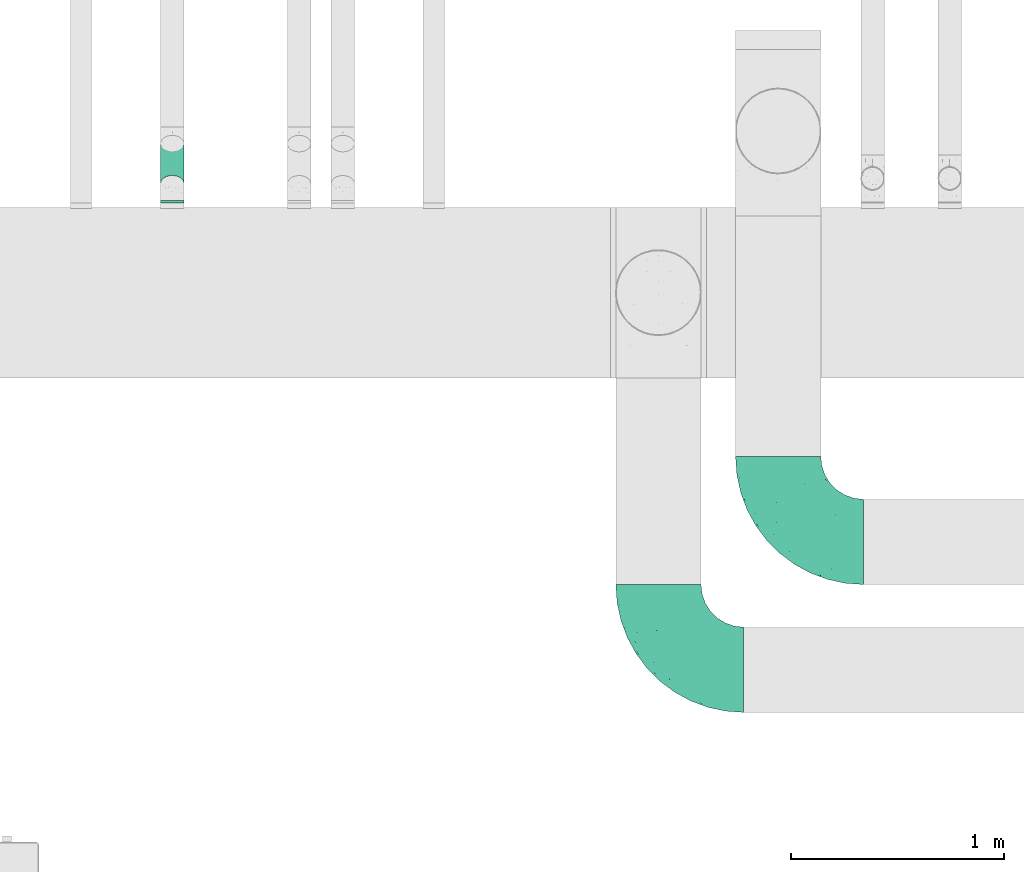
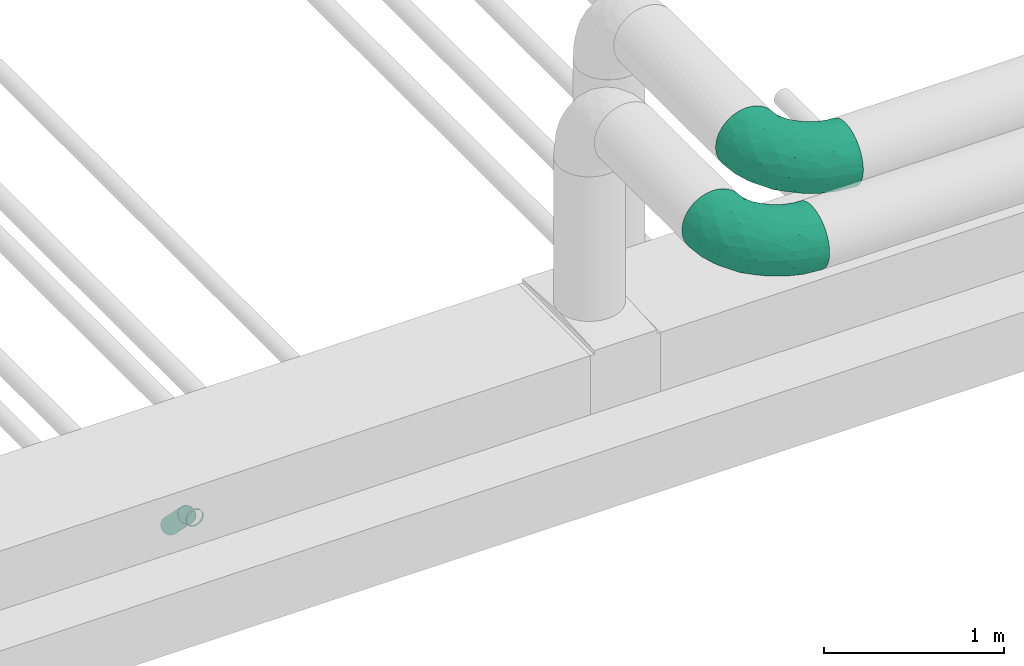
# One storey, part 32 of 91: 2 flow fittings, 2 flow segments.
"""IFC2X3 building model written with IfcOpenShell, lengths in millimetres."""

from ifc_helpers import new_model, entity, si_unit, converted_unit, derived_unit, direction, frame, origin_with_axes, origin_2d_with_axis, place, context, subcontext, project, spatial, hollow_circle, extrude, open_shell, surface_model, source, transform, mapped, material, layer, layer_set, layer_usage, type_object, element, save


model = new_model("IFC2X3")

# Units and contexts
model_context = context("Model", 3, precision=1e-05, world=origin_with_axes(), true_north=direction((0.0, 1.0)))
body_context = subcontext(model_context, "Body", "Model", "MODEL_VIEW")
ifc_project = project(units=[si_unit("AREAUNIT", "SQUARE_METRE"), si_unit("VOLUMEUNIT", "CUBIC_METRE", prefix="DECI"), si_unit("TIMEUNIT", "SECOND"), si_unit("THERMODYNAMICTEMPERATUREUNIT", "DEGREE_CELSIUS"), si_unit("PRESSUREUNIT", "PASCAL"), si_unit("MASSUNIT", "GRAM", prefix="KILO"), si_unit("LENGTHUNIT", "METRE", prefix="MILLI"), si_unit("POWERUNIT", "WATT"), si_unit("ELECTRICCURRENTUNIT", "AMPERE"), si_unit("ELECTRICVOLTAGEUNIT", "VOLT"), derived_unit("VOLUMETRICFLOWRATEUNIT", [(si_unit("VOLUMEUNIT", "CUBIC_METRE", prefix="DECI"), 1), (si_unit("TIMEUNIT", "SECOND"), -1)]), derived_unit("LINEARVELOCITYUNIT", [(si_unit("LENGTHUNIT", "METRE"), 1), (si_unit("TIMEUNIT", "SECOND"), -1)]), derived_unit("MASSDENSITYUNIT", [(si_unit("MASSUNIT", "GRAM", prefix="KILO"), 1), (si_unit("VOLUMEUNIT", "CUBIC_METRE"), -1)]), converted_unit("PLANEANGLEUNIT", "DEGREE", entity("IfcRatioMeasure", 0.01745), si_unit("PLANEANGLEUNIT", "RADIAN"), dimensions=[0, 0, 0, 0, 0, 0, 0])], contexts=[model_context])

# Site, building, storey
site_placement = place(None, origin_with_axes())
site = spatial("IfcSite", under=ifc_project, at=site_placement, CompositionType="ELEMENT")
building_placement = place(site_placement, origin_with_axes())
building = spatial("IfcBuilding", under=site, at=building_placement, Name="mc-building", CompositionType="ELEMENT")
storey_placement = place(building_placement, frame((0.0, 0.0, 8700.0), z_axis=(0.0, 0.0, 1.0), x_axis=(1.0, 0.0, 0.0)))
storey = spatial("IfcBuildingStorey", under=building, at=storey_placement, CompositionType="ELEMENT", Elevation=8700.0)

# Flow segments
ifc_material = material(Name="FZ1")
ifc_layer = layer(ifc_material, 0.0)
ifc_layer_set = layer_set([ifc_layer], Name="FZ1")
ifc_layer_usage = layer_usage(ifc_layer_set, "AXIS1", "POSITIVE", 0.0)
duct_segment_type = type_object("IfcDuctSegmentType", PredefinedType="RIGIDSEGMENT")
shared_shape_1 = source(origin_with_axes(), body_context, "Body", "SweptSolid", [
    extrude(hollow_circle(Radius=55.0, WallThickness=2.0, at=origin_2d_with_axis()), frame((0.0, 0.0, 0.0), z_axis=(1.0, 0.0, 0.0), x_axis=(0.0, 1.0, 0.0)), (0.0, 0.0, 1.0), 266.7),
])
flow_segment_1_placement = place(storey_placement, frame((14957.14677, 8401.1274, 635.78175), z_axis=(0.0, 0.707107, 0.707107), x_axis=(0.0, 0.707107, -0.707107)))
element("IfcFlowSegment", 1, at=flow_segment_1_placement, inside=storey, type_object=duct_segment_type, material=ifc_layer_usage, context=body_context, shape_type="MappedRepresentation", body=[
    mapped(shared_shape_1, transform((0.0, 0.0, 0.0), scale=1.0)),
])
shared_shape_2 = source(origin_with_axes(), body_context, "Body", "SweptSolid", [
    extrude(hollow_circle(Radius=55.0, WallThickness=2.0, at=origin_2d_with_axis()), frame((0.0, 0.0, 0.0), z_axis=(1.0, 0.0, 0.0), x_axis=(0.0, 1.0, 0.0)), (0.0, 0.0, 1.0), 13.0),
])
flow_segment_2_placement = place(storey_placement, frame((14957.14677, 8310.34565, 668.0), z_axis=(0.0, 0.0, 1.0), x_axis=(0.0, 1.0, 0.0)))
element("IfcFlowSegment", 2, at=flow_segment_2_placement, inside=storey, type_object=duct_segment_type, material=ifc_layer_usage, context=body_context, shape_type="MappedRepresentation", body=[
    mapped(shared_shape_2, transform((0.0, 0.0, 0.0), scale=1.0, scale2=1.0, scale3=1.0, uniform=False)),
])

# Flow fittings
duct_fitting_type = type_object("IfcDuctFittingType", Name="BU", PredefinedType="BEND")
shared_shape_3 = source(origin_with_axes(), body_context, "Body", "SurfaceModel", [
    surface_model("IfcShellBasedSurfaceModel", [(-400.0, 0.0, -200.0), (-400.0, -44.50419, -194.98559), (-400.0, 44.50419, -194.98559), (-400.0, 194.98559, 44.50419), (-400.0, 86.77674, -180.19378), (-400.0, 180.19378, -86.77674), (-400.0, 156.36629, -124.69796), (-400.0, 124.69796, -156.36629), (-400.0, -200.0, 0.0), (-400.0, -180.19378, 86.77674), (-400.0, -124.69796, -156.36629), (-400.0, -86.77674, -180.19378), (-400.0, -156.36629, -124.69796), (-400.0, -180.19378, -86.77674), (-400.0, -194.98559, -44.50419), (-400.0, 194.98559, -44.50419), (-400.0, 180.19378, 86.77674), (-400.0, 156.36629, 124.69796), (-400.0, 124.69796, 156.36629), (-400.0, 86.77674, 180.19378), (-400.0, 0.0, 200.0), (-400.0, 44.50419, 194.98559), (-400.0, -156.36629, 124.69796), (-400.0, -124.69796, 156.36629), (-400.0, -194.98559, 44.50419), (-400.0, -86.77674, 180.19378), (-400.0, -44.50419, 194.98559), (-400.0, 200.0, 0.0), (-194.98559, 400.0, 44.50419), (0.0, 400.0, -200.0), (-44.50419, 400.0, -194.98559), (-86.77674, 400.0, -180.19378), (-156.36629, 400.0, -124.69796), (-180.19378, 400.0, -86.77674), (-200.0, 400.0, 0.0), (-124.69796, 400.0, -156.36629), (156.36629, 400.0, -124.69796), (194.98559, 400.0, 44.50419), (86.77674, 400.0, -180.19378), (44.50419, 400.0, -194.98559), (124.69796, 400.0, -156.36629), (180.19378, 400.0, -86.77674), (194.98559, 400.0, -44.50419), (200.0, 400.0, 0.0), (-194.98559, 400.0, -44.50419), (-180.19378, 400.0, 86.77674), (-156.36629, 400.0, 124.69796), (-86.77674, 400.0, 180.19378), (-124.69796, 400.0, 156.36629), (-44.50419, 400.0, 194.98559), (124.69796, 400.0, 156.36629), (180.19378, 400.0, 86.77674), (156.36629, 400.0, 124.69796), (44.50419, 400.0, 194.98559), (86.77674, 400.0, 180.19378), (0.0, 400.0, 200.0), (-311.04439, 68.01314, 191.91169), (-360.46844, 68.4039, 188.77667), (-352.32006, 35.77277, 197.31443), (-330.54073, 6.0769, 200.0), (-263.19195, 24.12295, 200.0), (-213.51486, 270.31924, 100.59997), (-187.15609, 311.12218, 106.40641), (-204.91231, 317.36362, 67.86963), (-200.0, 53.58984, 200.0), (-197.74345, 111.1477, 194.30767), (-247.23242, 72.38885, 196.25526), (-256.68864, 256.68864, 32.58839), (-289.82519, 224.65778, 52.75457), (-248.54408, 248.5441, 73.99336), (-243.63371, 275.30204, 0.0), (-275.30204, 243.63371, 0.0), (-142.1827, 142.1827, 196.84374), (-142.88496, 93.58222, 200.0), (-271.45089, 124.32551, 175.54833), (-220.85071, 146.63576, 178.75804), (-259.76957, 175.46191, 147.316), (-350.66929, 110.58045, 169.34484), (-340.12953, 148.44794, 141.42136), (-308.54163, 188.2521, 106.4064), (-351.09401, 194.51642, 66.05581), (-361.24445, 172.62407, 106.40641), (-360.07224, 201.09774, 33.76184), (-300.36348, 163.70814, 139.24948), (-311.87682, 130.51714, 162.58441), (-194.26672, 352.15536, 66.05581), (-199.37996, 369.83655, 33.78914), (-206.63477, 338.94363, 33.20511), (-93.58222, 142.88496, 200.0), (-53.58984, 200.0, 200.0), (-111.1477, 197.74345, 194.30767), (-317.55983, 204.17269, 69.52389), (-333.06107, 208.69956, 32.59419), (-313.22325, 219.80622, 0.0), (-355.49582, 205.01441, 0.0), (-24.12295, 263.19195, 200.0), (-6.0769, 330.54073, 200.0), (-68.56573, 311.19245, 191.74293), (-217.40303, 217.40306, 141.07295), (-260.37399, 213.70418, 109.76458), (-125.42721, 271.96463, 174.87928), (-174.99626, 268.83246, 143.26342), (-163.21769, 225.3825, 169.72807), (-72.38885, 247.23242, 196.25526), (-35.77867, 352.31316, 197.31361), (-148.14225, 341.4288, 141.42136), (-110.51136, 351.07639, 169.34484), (-172.56981, 361.56427, 106.40641), (-224.65778, 289.82519, 52.75457), (-216.74424, 312.71216, 34.40997), (-68.38951, 360.58933, 188.77667), (-205.01441, 355.49582, 0.0), (-101.81453, 306.09531, 179.9031), (-130.71004, 312.65493, 162.27954), (-160.73603, 304.83801, 140.32812), (-143.50466, 203.50273, 184.62979), (-170.45511, 170.45511, 185.25303), (-314.32991, 100.10105, 179.54827), (-231.94286, 241.59953, 106.86055), (-203.62398, 249.73912, 129.12471), (-203.18683, 188.09564, 166.50592), (-219.80622, 313.22325, 0.0), (-361.56427, 172.56981, -106.40641), (-311.12218, 187.15609, -106.4064), (-341.4288, 148.14225, -141.42136), (-369.83655, 199.37996, -33.78914), (-360.58933, 68.38951, -188.77667), (-352.31316, 35.77867, -197.31361), (-304.83801, 160.73603, -140.32812), (-268.83248, 174.99626, -143.26341), (-271.96463, 125.42721, -174.87928), (-270.31924, 213.51487, -100.59997), (-351.07639, 110.51136, -169.34484), (-312.71216, 216.74424, -34.40997), (-289.82519, 224.65778, -52.75457), (-317.36362, 204.91231, -67.86963), (-352.15536, 194.26672, -66.05581), (-68.01314, 311.04439, -191.91169), (-68.4039, 360.4684, -188.77667), (-35.77277, 352.32006, -197.31443), (-142.1827, 142.1827, -196.84374), (-111.1477, 197.74345, -194.30767), (-93.58222, 142.88496, -200.0), (-142.88496, 93.58222, -200.0), (-200.0, 53.58984, -200.0), (-197.74345, 111.1477, -194.30767), (-204.17269, 317.55983, -69.52389), (-208.69954, 333.06107, -32.5942), (-194.51642, 351.09401, -66.05581), (-217.40303, 217.40306, -141.07295), (-213.70418, 260.37401, -109.76458), (-175.46191, 259.76955, -147.316), (-256.68864, 256.68864, -32.58839), (-247.23242, 72.38885, -196.25526), (-188.2521, 308.54167, -106.40641), (-172.62407, 361.24445, -106.40641), (-225.3825, 163.21769, -169.72807), (-203.50273, 143.50466, -184.62979), (-224.65778, 289.82519, -52.75457), (-248.54408, 248.5441, -73.99336), (-263.19195, 24.12295, -200.0), (-124.32551, 271.45089, -175.54831), (-163.70814, 300.36348, -139.24948), (-130.51714, 311.87682, -162.58441), (-148.44794, 340.12953, -141.42136), (-110.58045, 350.66929, -169.34484), (-201.09774, 360.07224, -33.76184), (-338.94363, 206.63477, -33.20511), (-146.63576, 220.85071, -178.75804), (-53.58984, 200.0, -200.0), (-72.38885, 247.23242, -196.25526), (-24.12295, 263.19195, -200.0), (-330.54073, 6.0769, -200.0), (-311.19245, 68.56573, -191.74293), (-6.0769, 330.54073, -200.0), (-306.09531, 101.81453, -179.9031), (-312.65497, 130.71004, -162.27954), (-170.45511, 170.45511, -185.25303), (-100.10105, 314.32991, -179.54827), (-241.59952, 231.94287, -106.86055), (-249.73912, 203.62398, -129.1247), (-188.09562, 203.18687, -166.50592), (-184.86177, -7.68945, -190.47945), (-47.3167, 68.9898, -181.64929), (43.28019, 97.94399, -146.26158), (-89.73868, -8.19462, -165.20748), (-284.08539, -23.9259, -196.06307), (-237.5194, -91.23123, -161.91366), (-285.29972, -62.21993, -184.899), (-107.30881, 56.88415, -193.38949), (-40.67465, 138.05292, -194.94777), (-131.25683, -108.81981, -96.04201), (-173.32759, -100.47387, -132.95037), (-35.15296, -20.32579, -124.42291), (108.22035, 131.82436, -97.48026), (127.15077, 249.03547, -134.14487), (162.73774, 297.11528, -101.94821), (45.84323, 55.57656, -115.34749), (15.96955, -15.96955, -67.48698), (-7.08356, -53.44974, 0.0), (53.44974, 7.08356, 0.0), (-304.96267, -182.15098, -62.88188), (66.48451, 298.1029, -184.38073), (23.16668, 169.83785, -182.54712), (22.2395, 260.55544, -194.94777), (-314.6111, -193.89287, 0.0), (-267.95143, -157.40498, -100.64249), (-150.75099, -145.7792, 0.0), (-230.96047, -175.69578, 0.0), (-197.18453, -157.02261, -53.19126), (-79.21044, -98.23441, -53.99454), (-294.12651, -135.91456, -136.39782), (156.86435, 197.34569, -53.92463), (98.27322, 80.18275, -55.7234), (101.78843, 289.17601, -164.41149), (86.29858, 191.80922, -152.84552), (97.15018, 155.27637, -127.46493), (182.19126, 305.22832, -62.89092), (104.75212, 75.61551, 0.0), (145.7792, 150.75099, 0.0), (-75.61551, -104.75212, 0.0), (193.89287, 314.6111, 0.0), (175.69578, 230.96047, 0.0), (98.27322, 80.18275, 55.7234), (-267.95143, -157.40498, 100.64249), (-197.18453, -157.02261, 53.19126), (-131.25683, -108.81981, 96.04201), (-304.96267, -182.15098, 62.88188), (108.22035, 131.82436, 97.48026), (156.86435, 197.34569, 53.92463), (162.73774, 297.11528, 101.94821), (-79.21044, -98.23441, 53.99454), (93.17167, 148.03003, 127.83594), (127.15077, 249.03547, 134.14487), (86.29858, 191.80922, 152.84552), (15.96955, -15.96955, 67.48698), (-173.32759, -100.47387, 132.95037), (-237.5194, -91.23123, 161.91366), (-294.12651, -135.91456, 136.39782), (-284.08539, -23.9259, 196.06307), (182.19126, 305.22832, 62.89092), (23.16668, 169.83785, 182.54712), (101.78843, 289.17601, 164.41149), (66.48451, 298.1029, 184.38073), (-107.30881, 56.88415, 193.38949), (-285.29972, -62.21993, 184.899), (-184.86177, -7.68945, 190.47945), (22.2395, 260.55544, 194.94777), (-40.67465, 138.05292, 194.94777), (-47.3167, 68.9898, 181.64929), (45.25548, 52.88294, 113.64735), (-89.73868, -8.19462, 165.20748), (43.28019, 97.94399, 146.26158), (-35.15296, -20.32579, 124.42291)], [open_shell([[[0, 1, 2]], [[2, 3, 4]], [[3, 5, 6]], [[6, 7, 3]], [[3, 7, 4]], [[2, 8, 9]], [[10, 8, 11]], [[2, 1, 11]], [[8, 12, 13]], [[13, 14, 8]], [[8, 10, 12]], [[11, 8, 2]], [[5, 3, 15]], [[2, 16, 3]], [[17, 16, 2]], [[18, 2, 19]], [[19, 2, 20]], [[2, 18, 17]], [[19, 20, 21]], [[22, 23, 9]], [[8, 24, 9]], [[25, 26, 20]], [[20, 23, 25]], [[9, 23, 20]], [[2, 9, 20]], [[27, 15, 3]], [[28, 29, 30]], [[31, 28, 30]], [[32, 33, 34]], [[34, 35, 32]], [[31, 35, 34]], [[36, 29, 37]], [[29, 38, 39]], [[29, 40, 38]], [[40, 29, 36]], [[36, 37, 41]], [[42, 41, 37]], [[42, 37, 43]], [[44, 34, 33]], [[28, 45, 29]], [[29, 45, 46]], [[47, 29, 48]], [[29, 47, 49]], [[46, 48, 29]], [[50, 29, 49]], [[51, 50, 52]], [[37, 29, 51]], [[53, 54, 49]], [[29, 50, 51]], [[49, 54, 50]], [[53, 49, 55]], [[34, 28, 31]], [[56, 57, 58]], [[20, 59, 58]], [[60, 56, 59]], [[61, 62, 63]], [[64, 65, 66]], [[67, 68, 69]], [[60, 64, 66]], [[70, 71, 67]], [[72, 65, 73]], [[74, 75, 76]], [[77, 18, 19]], [[64, 73, 65]], [[17, 18, 78]], [[79, 80, 81]], [[27, 3, 82]], [[74, 83, 84]], [[16, 17, 81]], [[85, 86, 87]], [[81, 17, 78]], [[19, 21, 57]], [[88, 89, 90]], [[80, 3, 16]], [[91, 92, 80]], [[78, 18, 77]], [[92, 93, 94]], [[95, 96, 97]], [[88, 72, 73]], [[66, 74, 56]], [[98, 99, 76]], [[71, 93, 68]], [[100, 101, 102]], [[103, 90, 89]], [[55, 49, 104]], [[28, 86, 85]], [[65, 75, 74]], [[105, 106, 48]], [[82, 80, 92]], [[90, 103, 100]], [[84, 78, 77]], [[46, 45, 107]], [[108, 109, 70]], [[46, 107, 105]], [[49, 110, 104]], [[63, 62, 85]], [[46, 105, 48]], [[45, 28, 85]], [[101, 62, 61]], [[48, 106, 47]], [[34, 111, 86]], [[70, 67, 108]], [[47, 110, 49]], [[105, 107, 62]], [[112, 106, 113]], [[114, 101, 100]], [[115, 100, 102]], [[90, 115, 72]], [[75, 65, 116]], [[89, 95, 103]], [[68, 93, 92]], [[99, 68, 79]], [[61, 108, 69]], [[63, 85, 87]], [[79, 81, 78]], [[80, 16, 81]], [[57, 77, 19]], [[117, 74, 84]], [[45, 85, 107]], [[62, 107, 85]], [[113, 106, 105]], [[106, 112, 110]], [[95, 97, 103]], [[103, 97, 112]], [[74, 66, 65]], [[56, 60, 66]], [[90, 72, 88]], [[65, 72, 116]], [[61, 118, 119]], [[113, 114, 100]], [[61, 119, 101]], [[98, 120, 102]], [[102, 101, 119]], [[115, 102, 116]], [[116, 120, 75]], [[75, 120, 76]], [[118, 98, 119]], [[84, 83, 78]], [[68, 99, 69]], [[79, 76, 99]], [[102, 120, 116]], [[76, 120, 98]], [[106, 110, 47]], [[104, 97, 96]], [[97, 104, 110]], [[55, 104, 96]], [[58, 57, 21]], [[57, 56, 117]], [[20, 58, 21]], [[56, 58, 59]], [[117, 84, 77]], [[83, 74, 76]], [[76, 79, 83]], [[79, 78, 83]], [[57, 117, 77]], [[74, 117, 56]], [[113, 105, 114]], [[112, 113, 100]], [[105, 62, 114]], [[62, 101, 114]], [[103, 112, 100]], [[112, 97, 110]], [[68, 67, 71]], [[108, 67, 69]], [[82, 92, 94]], [[80, 79, 91]], [[79, 68, 91]], [[68, 92, 91]], [[27, 82, 94]], [[3, 80, 82]], [[34, 86, 28]], [[87, 86, 111]], [[111, 121, 87]], [[109, 87, 121]], [[109, 63, 87]], [[61, 63, 108]], [[61, 69, 118]], [[102, 119, 98]], [[69, 99, 118]], [[98, 118, 99]], [[72, 115, 116]], [[100, 115, 90]], [[70, 109, 121]], [[63, 109, 108]], [[122, 123, 124]], [[125, 27, 94]], [[2, 126, 127]], [[128, 129, 130]], [[131, 129, 123]], [[7, 132, 4]], [[6, 124, 7]], [[133, 71, 134]], [[131, 123, 135]], [[136, 135, 123]], [[137, 138, 139]], [[140, 141, 142]], [[122, 6, 5]], [[143, 144, 145]], [[2, 127, 0]], [[146, 147, 148]], [[124, 132, 7]], [[149, 150, 151]], [[71, 70, 152]], [[145, 144, 153]], [[154, 148, 155]], [[153, 130, 145]], [[4, 126, 2]], [[130, 129, 156]], [[6, 122, 124]], [[140, 145, 157]], [[152, 158, 159]], [[144, 160, 153]], [[71, 152, 134]], [[161, 162, 163]], [[33, 148, 44]], [[155, 32, 164]], [[165, 35, 31]], [[44, 166, 34]], [[5, 15, 136]], [[32, 35, 164]], [[15, 125, 136]], [[33, 32, 155]], [[136, 125, 167]], [[165, 164, 35]], [[141, 168, 161]], [[142, 141, 169]], [[166, 148, 147]], [[170, 169, 141]], [[161, 168, 151]], [[147, 121, 111]], [[170, 171, 169]], [[160, 172, 173]], [[29, 174, 139]], [[70, 121, 158]], [[163, 164, 165]], [[171, 137, 174]], [[138, 31, 30]], [[175, 132, 176]], [[168, 141, 177]], [[142, 143, 140]], [[170, 161, 137]], [[157, 130, 156]], [[158, 121, 147]], [[150, 158, 154]], [[131, 134, 159]], [[135, 136, 167]], [[154, 155, 164]], [[148, 33, 155]], [[138, 165, 31]], [[178, 161, 163]], [[5, 136, 122]], [[123, 122, 136]], [[176, 132, 124]], [[132, 175, 126]], [[160, 173, 153]], [[153, 173, 175]], [[161, 170, 141]], [[137, 171, 170]], [[145, 140, 143]], [[141, 140, 177]], [[131, 179, 180]], [[176, 128, 130]], [[131, 180, 129]], [[149, 181, 156]], [[156, 129, 180]], [[157, 156, 177]], [[177, 181, 168]], [[168, 181, 151]], [[179, 149, 180]], [[163, 162, 164]], [[158, 150, 159]], [[154, 151, 150]], [[156, 181, 177]], [[151, 181, 149]], [[132, 126, 4]], [[127, 173, 172]], [[173, 127, 126]], [[0, 127, 172]], [[139, 138, 30]], [[138, 137, 178]], [[29, 139, 30]], [[137, 139, 174]], [[178, 163, 165]], [[162, 161, 151]], [[151, 154, 162]], [[154, 164, 162]], [[138, 178, 165]], [[161, 178, 137]], [[176, 124, 128]], [[175, 176, 130]], [[124, 123, 128]], [[123, 129, 128]], [[153, 175, 130]], [[175, 173, 126]], [[158, 152, 70]], [[134, 152, 159]], [[166, 147, 111]], [[148, 154, 146]], [[154, 158, 146]], [[158, 147, 146]], [[34, 166, 111]], [[44, 148, 166]], [[27, 125, 15]], [[167, 125, 94]], [[94, 93, 167]], [[133, 167, 93]], [[133, 135, 167]], [[131, 135, 134]], [[131, 159, 179]], [[156, 180, 149]], [[159, 150, 179]], [[149, 179, 150]], [[140, 157, 177]], [[130, 157, 145]], [[71, 133, 93]], [[135, 133, 134]], [[160, 144, 182]], [[183, 184, 185]], [[186, 1, 0]], [[187, 11, 188]], [[0, 172, 186]], [[182, 187, 188]], [[189, 142, 190]], [[191, 192, 193]], [[182, 186, 160]], [[182, 185, 187]], [[189, 144, 143]], [[194, 195, 196]], [[197, 198, 193]], [[199, 198, 200]], [[14, 13, 201]], [[202, 203, 204]], [[205, 8, 14]], [[182, 183, 185]], [[12, 206, 13]], [[184, 183, 203]], [[207, 208, 209]], [[207, 209, 210]], [[12, 211, 206]], [[14, 201, 205]], [[210, 191, 198]], [[182, 188, 186]], [[194, 212, 213]], [[193, 198, 191]], [[206, 211, 192]], [[214, 202, 38]], [[11, 187, 10]], [[215, 214, 195]], [[204, 171, 174]], [[40, 214, 38]], [[190, 204, 203]], [[169, 204, 190]], [[195, 216, 215]], [[12, 10, 211]], [[189, 183, 182]], [[188, 11, 1]], [[36, 195, 40]], [[208, 205, 201]], [[209, 201, 206]], [[204, 29, 39]], [[192, 191, 206]], [[191, 210, 209]], [[142, 169, 190]], [[198, 197, 213]], [[215, 203, 214]], [[196, 41, 217]], [[218, 213, 219]], [[210, 199, 220]], [[221, 222, 217]], [[29, 204, 174]], [[221, 42, 43]], [[212, 217, 222]], [[183, 190, 203]], [[40, 195, 214]], [[190, 183, 189]], [[212, 222, 219]], [[36, 41, 196]], [[213, 200, 198]], [[202, 39, 38]], [[171, 204, 169]], [[209, 206, 191]], [[42, 217, 41]], [[10, 187, 211]], [[211, 187, 192]], [[187, 185, 192]], [[193, 185, 184]], [[185, 193, 192]], [[193, 184, 197]], [[221, 217, 42]], [[212, 194, 196]], [[196, 217, 212]], [[195, 36, 196]], [[206, 201, 13]], [[201, 209, 208]], [[203, 202, 214]], [[39, 202, 204]], [[199, 210, 198]], [[207, 210, 220]], [[144, 189, 182]], [[142, 189, 143]], [[219, 213, 212]], [[200, 213, 218]], [[1, 186, 188]], [[160, 186, 172]], [[216, 195, 194]], [[203, 215, 184]], [[197, 216, 194]], [[184, 215, 216]], [[216, 197, 184]], [[197, 194, 213]], [[8, 205, 24]], [[223, 200, 218]], [[224, 225, 226]], [[208, 227, 205]], [[208, 225, 227]], [[228, 229, 230]], [[207, 220, 231]], [[232, 233, 234]], [[199, 235, 231]], [[236, 237, 238]], [[239, 60, 59]], [[225, 208, 207]], [[222, 221, 240]], [[199, 200, 235]], [[241, 242, 243]], [[23, 237, 25]], [[244, 88, 73]], [[239, 245, 246]], [[235, 226, 231]], [[55, 247, 53]], [[247, 243, 53]], [[20, 26, 239]], [[241, 248, 249]], [[60, 246, 64]], [[232, 250, 228]], [[245, 26, 25]], [[239, 26, 245]], [[22, 224, 238]], [[246, 244, 64]], [[249, 246, 251]], [[226, 225, 231]], [[24, 227, 9]], [[229, 240, 230]], [[233, 52, 50]], [[229, 219, 222]], [[22, 238, 23]], [[250, 223, 228]], [[229, 223, 219]], [[221, 43, 37]], [[250, 235, 223]], [[234, 241, 252]], [[240, 37, 51]], [[249, 248, 244]], [[221, 37, 240]], [[9, 224, 22]], [[51, 230, 240]], [[89, 88, 248]], [[244, 246, 249]], [[233, 242, 234]], [[247, 95, 89]], [[224, 9, 227]], [[242, 50, 54]], [[237, 246, 245]], [[96, 95, 247]], [[55, 96, 247]], [[247, 89, 248]], [[236, 253, 251]], [[249, 252, 241]], [[25, 237, 245]], [[241, 247, 248]], [[50, 242, 233]], [[236, 238, 224]], [[243, 242, 54]], [[229, 228, 223]], [[252, 249, 251]], [[246, 237, 251]], [[236, 224, 226]], [[237, 23, 238]], [[253, 236, 226]], [[251, 237, 236]], [[235, 253, 226]], [[251, 253, 252]], [[51, 52, 230]], [[240, 229, 222]], [[52, 233, 230]], [[228, 230, 233]], [[205, 227, 24]], [[224, 227, 225]], [[53, 243, 54]], [[241, 243, 247]], [[207, 231, 225]], [[199, 231, 220]], [[88, 244, 248]], [[64, 244, 73]], [[200, 223, 235]], [[219, 223, 218]], [[60, 239, 246]], [[239, 59, 20]], [[241, 234, 242]], [[232, 234, 252]], [[250, 252, 253]], [[233, 232, 228]], [[252, 250, 232]], [[235, 250, 253]]])]),
])
for number, where, z_axis, x_axis, name in (
    (3, (17238.01748, 6120.95522, 2971.08071), (0.0, 0.0, 1.0), (0.0, -1.0, 0.0), "BU"),
    (4, (17800.0, 6720.97227, 2971.08071), (0.0, 0.0, 1.0), (0.0, -1.0, 0.0), "BU"),
):
    element("IfcFlowFitting", number, at=place(storey_placement, frame(where, z_axis=z_axis, x_axis=x_axis)), inside=storey, type_object=duct_fitting_type, Name=name, context=body_context, shape_type="MappedRepresentation", body=[
        mapped(shared_shape_3, transform((0.0, 0.0, 0.0), scale=1.0)),
    ])

save(model, "model.ifc")
